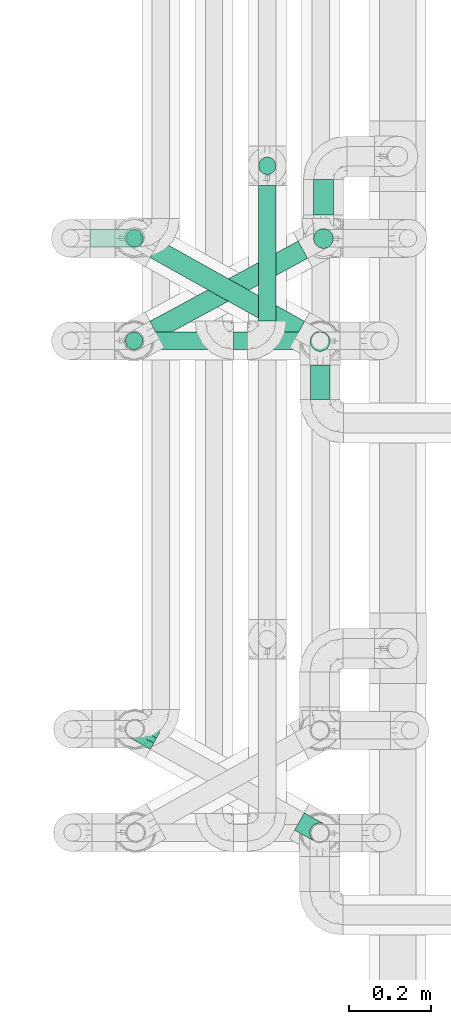
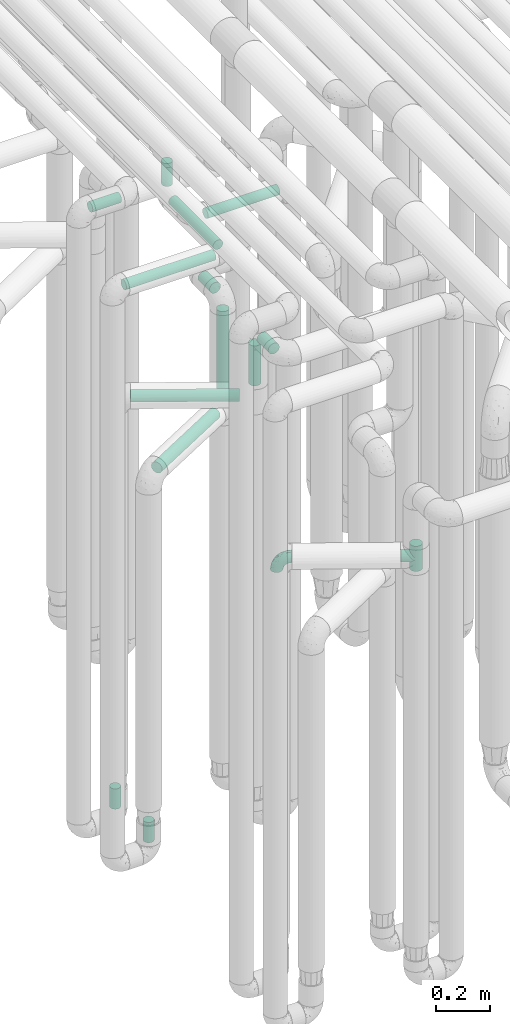
# One storey, part 599 of 827: 13 flow segments, 2 flow fittings.
"""IFC2X3 building model written with IfcOpenShell, lengths in millimetres."""

from ifc_helpers import new_model, entity, si_unit, converted_unit, derived_unit, direction, frame, origin, origin_2d_with_axis, place, context, subcontext, project, spatial, circle, extrude, faceted_brep, source, transform, mapped, material, type_object, type_shapes, element, save


model = new_model("IFC2X3")

# Units and contexts
model_context = context("Model", 3, precision=0.01, world=origin(), true_north=direction((6.12303176911189e-17, 1.0)))
body_context = subcontext(model_context, "Body", "Model", "MODEL_VIEW")
ifc_project = project(units=[si_unit("LENGTHUNIT", "METRE", prefix="MILLI"), si_unit("AREAUNIT", "SQUARE_METRE"), si_unit("VOLUMEUNIT", "CUBIC_METRE"), converted_unit("PLANEANGLEUNIT", "DEGREE", entity("IfcRatioMeasure", 0.0174532925199433), si_unit("PLANEANGLEUNIT", "RADIAN"), dimensions=[0, 0, 0, 0, 0, 0, 0]), si_unit("MASSUNIT", "GRAM", prefix="KILO"), derived_unit("MASSDENSITYUNIT", [(si_unit("MASSUNIT", "GRAM", prefix="KILO"), 1), (si_unit("LENGTHUNIT", "METRE"), -3)]), derived_unit("MOMENTOFINERTIAUNIT", [(si_unit("LENGTHUNIT", "METRE"), 4)]), si_unit("TIMEUNIT", "SECOND"), si_unit("FREQUENCYUNIT", "HERTZ"), si_unit("THERMODYNAMICTEMPERATUREUNIT", "DEGREE_CELSIUS"), derived_unit("THERMALTRANSMITTANCEUNIT", [(si_unit("MASSUNIT", "GRAM", prefix="KILO"), 1), (si_unit("THERMODYNAMICTEMPERATUREUNIT", "KELVIN"), -1), (si_unit("TIMEUNIT", "SECOND"), -3)]), derived_unit("VOLUMETRICFLOWRATEUNIT", [(si_unit("LENGTHUNIT", "METRE"), 3), (si_unit("TIMEUNIT", "SECOND"), -1)]), derived_unit("MASSFLOWRATEUNIT", [(si_unit("MASSUNIT", "GRAM", prefix="KILO"), 1), (si_unit("TIMEUNIT", "SECOND"), -1)]), derived_unit("ROTATIONALFREQUENCYUNIT", [(si_unit("TIMEUNIT", "SECOND"), -1)]), si_unit("ELECTRICCURRENTUNIT", "AMPERE"), si_unit("ELECTRICVOLTAGEUNIT", "VOLT"), si_unit("POWERUNIT", "WATT"), si_unit("FORCEUNIT", "NEWTON", prefix="KILO"), si_unit("ILLUMINANCEUNIT", "LUX"), si_unit("LUMINOUSFLUXUNIT", "LUMEN"), si_unit("LUMINOUSINTENSITYUNIT", "CANDELA"), derived_unit("USERDEFINED", [(si_unit("MASSUNIT", "GRAM", prefix="KILO"), -1), (si_unit("LENGTHUNIT", "METRE"), -2), (si_unit("TIMEUNIT", "SECOND"), 3), (si_unit("LUMINOUSFLUXUNIT", "LUMEN"), 1)]), derived_unit("LINEARVELOCITYUNIT", [(si_unit("LENGTHUNIT", "METRE"), 1), (si_unit("TIMEUNIT", "SECOND"), -1)]), si_unit("PRESSUREUNIT", "PASCAL"), derived_unit("USERDEFINED", [(si_unit("LENGTHUNIT", "METRE"), -2), (si_unit("MASSUNIT", "GRAM", prefix="KILO"), 1), (si_unit("TIMEUNIT", "SECOND"), -2)]), derived_unit("LINEARFORCEUNIT", [(si_unit("MASSUNIT", "GRAM", prefix="KILO"), 1), (si_unit("LENGTHUNIT", "METRE"), 1), (si_unit("TIMEUNIT", "SECOND"), -2), (si_unit("LENGTHUNIT", "METRE"), -1)]), derived_unit("PLANARFORCEUNIT", [(si_unit("MASSUNIT", "GRAM", prefix="KILO"), 1), (si_unit("LENGTHUNIT", "METRE"), 1), (si_unit("TIMEUNIT", "SECOND"), -2), (si_unit("LENGTHUNIT", "METRE"), -2)])], contexts=[model_context])

# Site, building, storey
site_placement = place(None, origin())
site = spatial("IfcSite", under=ifc_project, at=site_placement, CompositionType="ELEMENT")
building_placement = place(site_placement, origin())
building = spatial("IfcBuilding", under=site, at=building_placement, CompositionType="ELEMENT")
storey_placement = place(building_placement, frame((0.0, 0.0, 28200.0)))
storey = spatial("IfcBuildingStorey", under=building, at=storey_placement, Name="08", CompositionType="ELEMENT", Elevation=28200.0)

# Flow segments
pipe_segment_type = type_object("IfcPipeSegmentType", PredefinedType="NOTDEFINED")
flow_segment_1_placement = place(storey_placement, frame((35253.49, 11783.46, 448.0)))
element("IfcFlowSegment", 1, at=flow_segment_1_placement, inside=storey, type_object=pipe_segment_type, context=body_context, shape_type="SweptSolid", body=[
    extrude(circle(Radius=21.15, at=origin_2d_with_axis()), frame((22.75, 22.75, 0.0), z_axis=(0.0, 0.0, 1.0), x_axis=(-1.0, 0.0, 0.0)), (0.0, 0.0, 1.0), 92.0000000000094),
])
flow_segment_2_placement = place(storey_placement, frame((35252.29, 11533.46, 448.0)))
element("IfcFlowSegment", 2, at=flow_segment_2_placement, inside=storey, type_object=pipe_segment_type, context=body_context, shape_type="SweptSolid", body=[
    extrude(circle(Radius=21.15, at=origin_2d_with_axis()), frame((22.75, 22.75, 0.0), z_axis=(0.0, 0.0, 1.0), x_axis=(-1.0, 0.0, 0.0)), (0.0, 0.0, 1.0), 92.0000000000137),
])
flow_segment_3_placement = place(storey_placement, frame((35168.03, 11783.46, 3177.25)))
element("IfcFlowSegment", 3, at=flow_segment_3_placement, inside=storey, type_object=pipe_segment_type, context=body_context, shape_type="SweptSolid", body=[
    extrude(circle(Radius=21.15, at=origin_2d_with_axis()), frame((0.0, 22.75, 22.75), z_axis=(1.0, 0.0, 0.0), x_axis=(0.0, -1.0, 0.0)), (0.0, 0.0, 1.0), 124.000000000024),
])
flow_segment_4_placement = place(storey_placement, frame((35518.03, 11533.42, 3177.25)))
element("IfcFlowSegment", 4, at=flow_segment_4_placement, inside=storey, type_object=pipe_segment_type, context=body_context, shape_type="SweptSolid", body=[
    extrude(circle(Radius=21.15, at=origin_2d_with_axis()), frame((0.0, 22.75, 22.75), z_axis=(1.0, 0.0, 0.0), x_axis=(0.0, 1.0, 0.0)), (0.0, 0.0, 1.0), 307.750000000047),
])
flow_segment_5_placement = place(storey_placement, frame((35168.03, 11533.44, 2977.25)))
element("IfcFlowSegment", 5, at=flow_segment_5_placement, inside=storey, type_object=pipe_segment_type, context=body_context, shape_type="SweptSolid", body=[
    extrude(circle(Radius=21.15, at=origin_2d_with_axis()), frame((0.0, 22.76, 22.75), z_axis=(1.0, -4.58022354030143e-05, 0.0), x_axis=(4.58022354030143e-05, 1.0, 0.0)), (0.0, 0.0, 1.0), 384.054937940216),
])
flow_segment_6_placement = place(storey_placement, frame((35577.35, 11604.18, 2977.25)))
element("IfcFlowSegment", 6, at=flow_segment_6_placement, inside=storey, type_object=pipe_segment_type, context=body_context, shape_type="SweptSolid", body=[
    extrude(circle(Radius=21.15, at=origin_2d_with_axis()), frame((22.75, 0.0, 22.75), z_axis=(0.0, 1.0, 0.0), x_axis=(-1.0, 0.0, 0.0)), (0.0, 0.0, 1.0), 331.019903361199),
])
flow_segment_7_placement = place(storey_placement, frame((35577.35, 11960.46, 3048.0)))
element("IfcFlowSegment", 7, at=flow_segment_7_placement, inside=storey, type_object=pipe_segment_type, context=body_context, shape_type="SweptSolid", body=[
    extrude(circle(Radius=21.15, at=origin_2d_with_axis()), frame((22.75, 22.75, 0.0)), (0.0, 0.0, 1.0), 104.000000000011),
])
flow_segment_8_placement = place(storey_placement, frame((35711.26, 11780.07, 2157.0)))
element("IfcFlowSegment", 8, at=flow_segment_8_placement, inside=storey, type_object=pipe_segment_type, context=body_context, shape_type="SweptSolid", body=[
    extrude(circle(Radius=24.0, at=origin_2d_with_axis()), frame((25.6, 25.6, 0.0), z_axis=(0.0, 0.0, 1.0), x_axis=(-1.0, 0.0, 0.0)), (0.0, 0.0, 1.0), 385.99999999999),
])
flow_segment_9_placement = place(storey_placement, frame((35703.19, 11528.87, 2362.0)))
element("IfcFlowSegment", 9, at=flow_segment_9_placement, inside=storey, type_object=pipe_segment_type, context=body_context, shape_type="SweptSolid", body=[
    extrude(circle(Radius=24.0, at=origin_2d_with_axis()), frame((25.6, 25.6, 0.0), z_axis=(0.0, 0.0, 1.0), x_axis=(-1.0, 0.0, 0.0)), (0.0, 0.0, 1.0), 180.999999999998),
])
flow_segment_10_placement = place(storey_placement, frame((35312.67, 11560.12, 2279.4)))
element("IfcFlowSegment", 10, at=flow_segment_10_placement, inside=storey, type_object=pipe_segment_type, context=body_context, shape_type="SweptSolid", body=[
    extrude(circle(Radius=24.0, at=origin_2d_with_axis()), frame((13.31, 220.18, 25.6), z_axis=(0.872709848733326, -0.488239203591698, 0.0), x_axis=(-0.488239203591698, -0.872709848733326, 0.0)), (0.0, 0.0, 1.0), 404.791381976554),
])
flow_segment_11_placement = place(storey_placement, frame((35312.16, 11560.04, 2074.4)))
element("IfcFlowSegment", 11, at=flow_segment_11_placement, inside=storey, type_object=pipe_segment_type, context=body_context, shape_type="SweptSolid", body=[
    extrude(circle(Radius=24.0, at=origin_2d_with_axis()), frame((13.02, 22.7, 25.6), z_axis=(0.879349860952551, 0.47617625102763, 0.0), x_axis=(0.47617625102763, -0.879349860952551, 0.0)), (0.0, 0.0, 1.0), 411.156212335712),
])
flow_segment_12_placement = place(storey_placement, frame((35711.26, 11862.67, 2574.4)))
element("IfcFlowSegment", 12, at=flow_segment_12_placement, inside=storey, type_object=pipe_segment_type, context=body_context, shape_type="SweptSolid", body=[
    extrude(circle(Radius=24.0, at=origin_2d_with_axis()), frame((25.6, 0.0, 25.6), z_axis=(0.0, 1.0, 0.0), x_axis=(1.0, 0.0, 0.0)), (0.0, 0.0, 1.0), 86.4113062809591),
])
flow_segment_13_placement = place(storey_placement, frame((35703.19, 11413.08, 2574.4)))
element("IfcFlowSegment", 13, at=flow_segment_13_placement, inside=storey, type_object=pipe_segment_type, context=body_context, shape_type="SweptSolid", body=[
    extrude(circle(Radius=24.0, at=origin_2d_with_axis()), frame((25.6, 0.0, 25.6), z_axis=(0.0, 1.0, 0.0), x_axis=(-1.0, 0.0, 0.0)), (0.0, 0.0, 1.0), 84.3822522691391),
])

# Flow fittings
ifc_material = material()
pipe_fitting_type_1 = type_object("IfcPipeFittingType", Name="ADSK_1", PredefinedType="NOTDEFINED", material=ifc_material)
shared_shape_1 = source(origin(), body_context, "Body", "Brep", [
    faceted_brep([(-57.0, 12.07, -20.91), (-57.0, 6.25, -23.33), (-57.0, 0.0, -24.15), (-57.0, -6.25, -23.33), (-57.0, -12.08, -20.91), (-57.0, -17.08, -17.08), (-57.0, -20.91, -12.08), (-57.0, -23.33, -6.25), (-57.0, -24.15, 0.0), (-57.0, -23.33, 6.25), (-57.0, -20.91, 12.07), (-57.0, -17.08, 17.08), (-57.0, -12.08, 20.91), (-57.0, -6.25, 23.33), (-57.0, 0.0, 24.15), (-57.0, 6.25, 23.33), (-57.0, 12.07, 20.91), (-57.0, 17.08, 17.08), (-57.0, 20.91, 12.07), (-57.0, 23.33, 6.25), (-57.0, 24.15, 0.0), (-57.0, 23.33, -6.25), (-57.0, 20.91, -12.08), (-57.0, 17.08, -17.08), (0.0, 57.0, -24.15), (-6.25, 57.0, -23.33), (-12.07, 57.0, -20.91), (-17.08, 57.0, -17.08), (-20.91, 57.0, -12.08), (-23.33, 57.0, -6.25), (-24.15, 57.0, 0.0), (-23.33, 57.0, 6.25), (-20.91, 57.0, 12.07), (-17.08, 57.0, 17.08), (-12.07, 57.0, 20.91), (-6.25, 57.0, 23.33), (0.0, 57.0, 24.15), (6.25, 57.0, 23.33), (12.08, 57.0, 20.91), (17.08, 57.0, 17.08), (20.91, 57.0, 12.07), (23.33, 57.0, 6.25), (24.15, 57.0, 0.0), (23.33, 57.0, -6.25), (20.91, 57.0, -12.08), (17.08, 57.0, -17.08), (12.08, 57.0, -20.91), (6.25, 57.0, -23.33), (14.9, 21.14, 6.17), (13.61, 24.64, 12.48), (6.23, 8.95, 8.98), (-41.47, -21.06, 0.0), (-41.92, -18.38, 13.72), (-24.64, -13.61, 12.48), (-37.37, -13.24, 18.15), (-6.8, -4.93, 8.18), (-21.76, -15.19, 6.22), (-12.78, -9.18, 0.0), (-37.73, -20.51, 7.75), (-7.38, 7.38, 20.24), (-23.37, -4.26, 20.42), (-11.9, -3.19, 15.86), (-42.14, -8.7, 21.82), (13.24, 37.37, 18.15), (9.33, 23.53, 16.85), (4.26, 23.37, 20.42), (2.77, 10.92, 15.55), (-29.46, 0.91, 23.52), (-44.13, 20.56, 15.69), (-39.25, 26.33, 10.88), (-49.02, 22.92, 9.96), (-34.58, 23.87, 17.15), (-15.8, 6.8, 22.81), (-8.67, 20.47, 23.88), (-18.12, 12.9, 24.08), (-48.29, 14.92, 19.65), (-44.06, -2.85, 23.78), (-9.23, 48.95, 22.58), (-3.78, 42.74, 24.07), (-40.34, 4.26, 24.09), (-44.02, 26.14, 5.46), (-44.04, 9.88, 22.74), (-4.95, 16.87, 22.52), (-2.75, 1.43, 12.5), (-25.48, 40.98, 10.71), (20.51, 37.73, 7.75), (18.38, 41.92, 13.72), (8.7, 42.14, 21.82), (-25.95, -17.97, 0.0), (2.85, 44.06, 23.78), (21.06, 41.47, 0.0), (17.97, 25.95, 0.0), (-24.04, -9.27, 17.13), (-33.26, 33.26, 5.86), (-28.55, 40.57, 0.0), (-40.57, 28.55, 0.0), (-25.29, 47.19, 4.06), (-27.01, 31.1, 16.77), (-15.7, 43.95, 19.9), (-20.27, 45.22, 15.61), (-30.53, 31.98, 12.64), (-11.28, 38.33, 22.92), (-9.97, 27.88, 24.09), (-20.15, 30.26, 21.25), (-31.25, 11.75, 23.64), (-28.75, 7.23, 24.15), (-29.53, 18.06, 22.27), (-28.44, 24.21, 20.02), (-37.55, 17.7, 20.26), (-15.88, 29.25, 22.99), (-20.82, 20.82, 23.44), (-0.91, 29.46, 23.52), (-13.5, -7.67, 12.04), (1.49, 1.56, 5.16), (8.86, 10.35, 4.59), (0.38, -0.38, 0.0), (9.18, 12.78, 0.0), (-37.37, -13.24, -18.15), (8.86, 10.35, -4.59), (-45.22, 20.27, -15.61), (-43.95, 15.7, -19.9), (-38.33, 11.28, -22.92), (-48.95, 9.23, -22.58), (-47.19, 25.29, -4.06), (-33.26, 33.26, -5.86), (18.38, 41.92, -13.72), (-30.26, 20.15, -21.25), (2.85, 44.06, -23.78), (-4.26, 40.34, -24.09), (-40.98, 25.48, -10.71), (-41.92, -18.38, -13.72), (9.25, 23.5, -16.92), (4.26, 23.37, -20.42), (13.24, 37.37, -18.15), (-37.73, -20.51, -7.75), (-11.75, 31.25, -23.64), (-7.23, 28.75, -24.15), (-12.9, 18.12, -24.08), (8.7, 42.14, -21.82), (-44.06, -2.85, -23.78), (-6.8, 15.8, -22.81), (-20.47, 8.67, -23.88), (-24.64, -13.61, -12.48), (-42.74, 3.78, -24.07), (-18.06, 29.53, -22.27), (-24.21, 28.44, -20.02), (-27.88, 9.97, -24.09), (-31.1, 27.01, -16.77), (-26.14, 44.02, -5.46), (14.9, 21.14, -6.17), (20.51, 37.73, -7.75), (-9.88, 44.04, -22.74), (-20.56, 44.13, -15.69), (-21.76, -15.19, -6.22), (-13.5, -7.67, -12.04), (-24.14, -9.76, -16.74), (-11.9, -3.19, -15.86), (-14.92, 48.29, -19.65), (-23.37, -4.26, -20.42), (-0.91, 29.46, -23.52), (-26.33, 39.25, -10.88), (-23.87, 34.58, -17.15), (-42.14, -8.7, -21.82), (-22.92, 49.02, -9.96), (13.61, 24.64, -12.48), (-31.98, 30.53, -12.64), (-16.87, 4.95, -22.52), (-17.7, 37.55, -20.26), (-29.25, 15.88, -22.99), (-20.82, 20.82, -23.44), (-29.46, 0.91, -23.52), (-7.38, 7.38, -20.24), (2.77, 10.92, -15.55), (6.23, 8.95, -8.98), (-6.8, -4.93, -8.18), (-2.81, 1.41, -12.54), (1.49, 1.56, -5.16)], [[[0, 1, 2, 3, 4, 5, 6, 7, 8, 9, 10, 11, 12, 13, 14, 15, 16, 17, 18, 19, 20, 21, 22, 23]], [[24, 25, 26, 27, 28, 29, 30, 31, 32, 33, 34, 35, 36, 37, 38, 39, 40, 41, 42, 43, 44, 45, 46, 47]], [[48, 49, 50]], [[9, 8, 51]], [[52, 53, 54]], [[55, 56, 57]], [[10, 58, 52]], [[9, 58, 10]], [[59, 60, 61]], [[54, 12, 11]], [[54, 62, 12]], [[63, 39, 38]], [[64, 65, 66]], [[62, 60, 67]], [[68, 69, 70]], [[71, 69, 68]], [[72, 73, 74]], [[16, 75, 17]], [[13, 76, 14]], [[35, 77, 78]], [[14, 79, 15]], [[17, 68, 18]], [[14, 76, 79]], [[20, 19, 80]], [[70, 19, 18]], [[81, 15, 79]], [[15, 81, 16]], [[73, 72, 82]], [[66, 83, 50]], [[32, 31, 84]], [[85, 86, 49]], [[63, 87, 65]], [[56, 58, 88]], [[36, 89, 37]], [[85, 41, 40]], [[36, 35, 78]], [[90, 41, 85]], [[40, 39, 86]], [[12, 62, 13]], [[86, 85, 40]], [[48, 85, 49]], [[85, 91, 90]], [[87, 38, 37]], [[92, 60, 54]], [[80, 69, 93]], [[93, 94, 95]], [[10, 52, 11]], [[94, 96, 30]], [[97, 98, 99]], [[80, 93, 95]], [[100, 97, 84]], [[99, 98, 33]], [[101, 102, 78]], [[103, 101, 98]], [[96, 31, 30]], [[77, 98, 101]], [[77, 35, 34]], [[34, 33, 98]], [[9, 51, 58]], [[87, 63, 38]], [[104, 105, 74]], [[106, 103, 107]], [[106, 81, 104]], [[75, 68, 17]], [[108, 107, 71]], [[33, 32, 99]], [[109, 103, 110]], [[101, 109, 102]], [[89, 78, 111]], [[53, 52, 58]], [[54, 11, 52]], [[60, 62, 54]], [[88, 58, 51]], [[76, 62, 67]], [[53, 112, 92]], [[60, 59, 72]], [[39, 63, 86]], [[49, 86, 63]], [[89, 87, 37]], [[42, 41, 90]], [[111, 82, 65]], [[111, 65, 87]], [[65, 59, 66]], [[104, 81, 79]], [[75, 81, 108]], [[32, 84, 99]], [[97, 99, 84]], [[98, 97, 103]], [[106, 107, 108]], [[74, 102, 110]], [[111, 78, 102]], [[74, 110, 104]], [[74, 67, 72]], [[61, 92, 112]], [[66, 59, 61]], [[56, 53, 58]], [[66, 50, 49]], [[61, 112, 83]], [[66, 49, 64]], [[78, 89, 36]], [[87, 89, 111]], [[62, 76, 13]], [[79, 76, 67]], [[100, 93, 69]], [[96, 93, 84]], [[55, 113, 50]], [[113, 114, 50]], [[104, 79, 105]], [[106, 104, 110]], [[20, 80, 95]], [[85, 48, 91]], [[115, 114, 113]], [[116, 91, 48]], [[70, 80, 19]], [[93, 96, 94]], [[84, 31, 96]], [[103, 106, 110]], [[81, 106, 108]], [[103, 97, 107]], [[71, 107, 97]], [[71, 97, 100]], [[108, 71, 68]], [[79, 67, 105]], [[67, 74, 105]], [[115, 113, 57]], [[112, 56, 55]], [[56, 88, 57]], [[60, 72, 67]], [[82, 72, 59]], [[65, 82, 59]], [[82, 111, 73]], [[111, 102, 73]], [[102, 74, 73]], [[81, 75, 16]], [[68, 75, 108]], [[68, 70, 18]], [[80, 70, 69]], [[98, 77, 34]], [[78, 77, 101]], [[93, 100, 84]], [[71, 100, 69]], [[102, 109, 110]], [[101, 103, 109]], [[53, 92, 54]], [[61, 60, 92]], [[56, 112, 53]], [[83, 112, 55]], [[50, 83, 55]], [[61, 83, 66]], [[49, 63, 64]], [[65, 64, 63]], [[57, 113, 55]], [[114, 115, 116]], [[116, 48, 114]], [[48, 50, 114]], [[117, 5, 4]], [[116, 115, 118]], [[119, 120, 23]], [[121, 122, 120]], [[95, 123, 20]], [[0, 23, 120]], [[124, 95, 94]], [[125, 45, 44]], [[121, 120, 126]], [[24, 127, 128]], [[22, 21, 129]], [[0, 122, 1]], [[5, 117, 130]], [[131, 132, 133]], [[134, 88, 51]], [[135, 136, 137]], [[6, 5, 130]], [[46, 138, 47]], [[139, 3, 2]], [[140, 141, 137]], [[6, 134, 7]], [[134, 130, 142]], [[143, 2, 1]], [[144, 126, 145]], [[121, 146, 143]], [[147, 120, 119]], [[94, 148, 124]], [[149, 150, 91]], [[30, 29, 148]], [[151, 25, 128]], [[27, 152, 28]], [[134, 153, 88]], [[154, 155, 156]], [[27, 26, 157]], [[151, 26, 25]], [[155, 158, 156]], [[24, 47, 127]], [[1, 122, 143]], [[138, 132, 159]], [[160, 152, 161]], [[24, 128, 25]], [[46, 133, 138]], [[162, 117, 4]], [[148, 160, 124]], [[152, 160, 163]], [[154, 142, 155]], [[45, 125, 133]], [[133, 46, 45]], [[125, 164, 133]], [[51, 7, 134]], [[42, 90, 43]], [[165, 147, 129]], [[153, 134, 142]], [[43, 150, 44]], [[162, 4, 3]], [[141, 140, 166]], [[117, 162, 158]], [[163, 29, 28]], [[43, 90, 150]], [[123, 21, 20]], [[144, 151, 135]], [[157, 152, 27]], [[167, 145, 161]], [[23, 22, 119]], [[168, 126, 169]], [[121, 168, 146]], [[139, 143, 170]], [[142, 130, 117]], [[8, 7, 51]], [[134, 6, 130]], [[139, 162, 3]], [[170, 166, 158]], [[170, 158, 162]], [[158, 171, 156]], [[44, 150, 125]], [[91, 150, 90]], [[164, 125, 150]], [[132, 138, 133]], [[127, 138, 159]], [[131, 164, 172]], [[132, 171, 140]], [[135, 151, 128]], [[157, 151, 167]], [[22, 129, 119]], [[147, 119, 129]], [[120, 147, 126]], [[144, 145, 167]], [[137, 146, 169]], [[170, 143, 146]], [[137, 169, 135]], [[137, 159, 140]], [[171, 172, 156]], [[173, 174, 175]], [[156, 175, 154]], [[174, 57, 153]], [[132, 172, 171]], [[172, 164, 173]], [[143, 139, 2]], [[162, 139, 170]], [[138, 127, 47]], [[128, 127, 159]], [[165, 124, 160]], [[123, 124, 129]], [[149, 173, 164]], [[176, 174, 173]], [[135, 128, 136]], [[144, 135, 169]], [[150, 149, 164]], [[176, 118, 115]], [[149, 91, 116]], [[30, 148, 94]], [[163, 148, 29]], [[124, 123, 95]], [[129, 21, 123]], [[126, 144, 169]], [[151, 144, 167]], [[126, 147, 145]], [[161, 145, 147]], [[161, 147, 165]], [[167, 161, 152]], [[128, 159, 136]], [[159, 137, 136]], [[154, 153, 142]], [[132, 140, 159]], [[174, 176, 57]], [[57, 88, 153]], [[166, 140, 171]], [[158, 166, 171]], [[166, 170, 141]], [[170, 146, 141]], [[146, 137, 141]], [[151, 157, 26]], [[152, 157, 167]], [[152, 163, 28]], [[148, 163, 160]], [[120, 122, 0]], [[143, 122, 121]], [[124, 165, 129]], [[161, 165, 160]], [[146, 168, 169]], [[121, 126, 168]], [[142, 117, 155]], [[158, 155, 117]], [[175, 156, 172]], [[153, 154, 174]], [[173, 175, 172]], [[174, 154, 175]], [[164, 131, 133]], [[172, 132, 131]], [[176, 173, 118]], [[57, 176, 115]], [[173, 149, 118]], [[149, 116, 118]]]),
])
type_shapes(pipe_fitting_type_1, [shared_shape_1])
flow_fitting_1_placement = place(storey_placement, frame((35276.74, 10609.13, 2305.0), z_axis=(-0.4889196285334, -0.872328835264983, 0.0), x_axis=(-0.872328835264983, 0.4889196285334, 0.0)))
element("IfcFlowFitting", 14, at=flow_fitting_1_placement, inside=storey, type_object=pipe_fitting_type_1, material=ifc_material, Name="ADSK_1", ObjectType="ADSK_1", context=body_context, shape_type="MappedRepresentation", body=[
    mapped(shared_shape_1, transform((0.0, 0.0, 0.0), scale=1.0)),
])
pipe_fitting_type_2 = type_object("IfcPipeFittingType", Name="ADSK_1", PredefinedType="NOTDEFINED", material=ifc_material)
shared_shape_2 = source(origin(), body_context, "Body", "Brep", [
    faceted_brep([(-57.0, 12.07, -20.91), (-57.0, 6.25, -23.33), (-57.0, 0.0, -24.15), (-57.0, -6.25, -23.33), (-57.0, -12.08, -20.91), (-57.0, -17.08, -17.08), (-57.0, -20.91, -12.08), (-57.0, -23.33, -6.25), (-57.0, -24.15, 0.0), (-57.0, -23.33, 6.25), (-57.0, -20.91, 12.07), (-57.0, -17.08, 17.08), (-57.0, -12.08, 20.91), (-57.0, -6.25, 23.33), (-57.0, 0.0, 24.15), (-57.0, 6.25, 23.33), (-57.0, 12.07, 20.91), (-57.0, 17.08, 17.08), (-57.0, 20.91, 12.07), (-57.0, 23.33, 6.25), (-57.0, 24.15, 0.0), (-57.0, 23.33, -6.25), (-57.0, 20.91, -12.08), (-57.0, 17.08, -17.08), (57.0, 0.0, -24.15), (57.0, 6.25, -23.33), (57.0, 12.07, -20.91), (57.0, 17.08, -17.08), (57.0, 20.91, -12.08), (57.0, 23.33, -6.25), (57.0, 24.15, 0.0), (57.0, 23.33, 6.25), (57.0, 20.91, 12.07), (57.0, 17.08, 17.08), (57.0, 12.07, 20.91), (57.0, 6.25, 23.33), (57.0, 0.0, 24.15), (57.0, -6.25, 23.33), (57.0, -12.08, 20.91), (57.0, -17.08, 17.08), (57.0, -20.91, 12.07), (57.0, -23.33, 6.25), (57.0, -24.15, 0.0), (57.0, -23.33, -6.25), (57.0, -20.91, -12.08), (57.0, -17.08, -17.08), (57.0, -12.08, -20.91), (57.0, -6.25, -23.33), (23.27, -23.27, 6.45), (24.15, -24.15, 0.0), (-24.15, -24.15, 0.0), (20.9, -20.9, 12.1), (13.54, -13.54, 20.0), (17.52, -17.52, 16.62), (-23.27, -23.27, 6.45), (-20.9, -20.9, 12.1), (-17.52, -17.52, 16.62), (-13.54, -13.54, 20.0), (-9.19, -9.19, 22.33), (9.19, -9.19, 22.33), (4.64, -4.64, 23.7), (0.0, 0.0, 24.15), (-4.64, -4.64, 23.7), (4.64, -4.64, -23.7), (0.0, 0.0, -24.15), (-4.64, -4.64, -23.7), (-9.19, -9.19, -22.33), (9.19, -9.19, -22.33), (13.54, -13.54, -20.0), (17.52, -17.52, -16.62), (20.9, -20.9, -12.1), (23.27, -23.27, -6.45), (-13.54, -13.54, -20.0), (-17.52, -17.52, -16.62), (-23.27, -23.27, -6.45), (-20.9, -20.9, -12.1), (0.0, -57.0, -24.15), (6.25, -57.0, -23.33), (12.08, -57.0, -20.91), (17.08, -57.0, -17.08), (20.91, -57.0, -12.08), (23.33, -57.0, -6.25), (24.15, -57.0, 0.0), (23.33, -57.0, 6.25), (20.91, -57.0, 12.07), (17.08, -57.0, 17.08), (12.08, -57.0, 20.91), (6.25, -57.0, 23.33), (0.0, -57.0, 24.15), (-6.25, -57.0, 23.33), (-12.07, -57.0, 20.91), (-17.08, -57.0, 17.08), (-20.91, -57.0, 12.07), (-23.33, -57.0, 6.25), (-24.15, -57.0, 0.0), (-23.33, -57.0, -6.25), (-20.91, -57.0, -12.08), (-17.08, -57.0, -17.08), (-12.07, -57.0, -20.91), (-6.25, -57.0, -23.33)], [[[0, 1, 2, 3, 4, 5, 6, 7, 8, 9, 10, 11, 12, 13, 14, 15, 16, 17, 18, 19, 20, 21, 22, 23]], [[24, 25, 26, 27, 28, 29, 30, 31, 32, 33, 34, 35, 36, 37, 38, 39, 40, 41, 42, 43, 44, 45, 46, 47]], [[41, 40, 48]], [[42, 41, 49]], [[50, 9, 8]], [[49, 41, 48]], [[40, 51, 48]], [[39, 38, 52]], [[51, 40, 53]], [[52, 53, 39]], [[53, 40, 39]], [[50, 54, 9]], [[9, 54, 10]], [[54, 55, 10]], [[56, 57, 11]], [[11, 10, 56]], [[11, 57, 12]], [[56, 10, 55]], [[12, 57, 58]], [[52, 38, 59]], [[60, 36, 61]], [[62, 61, 14]], [[59, 37, 60]], [[37, 59, 38]], [[60, 37, 36]], [[61, 36, 35, 15, 14]], [[32, 31, 19, 18]], [[17, 16, 34, 33]], [[18, 17, 33, 32]], [[35, 34, 16, 15]], [[20, 19, 31, 30]], [[62, 13, 58]], [[13, 62, 14]], [[58, 13, 12]], [[27, 23, 22, 28]], [[22, 21, 29, 28]], [[0, 23, 27, 26]], [[20, 30, 29, 21]], [[24, 47, 63]], [[24, 64, 2, 1, 25]], [[64, 24, 63]], [[2, 64, 65]], [[26, 25, 1, 0]], [[65, 66, 3]], [[2, 65, 3]], [[66, 4, 3]], [[63, 47, 67]], [[46, 45, 68]], [[69, 68, 45]], [[44, 70, 69]], [[69, 45, 44]], [[46, 68, 67]], [[43, 42, 49]], [[7, 50, 8]], [[43, 71, 44]], [[71, 43, 49]], [[44, 71, 70]], [[72, 4, 66]], [[72, 5, 4]], [[5, 72, 73]], [[5, 73, 6]], [[74, 50, 7]], [[75, 74, 6]], [[74, 7, 6]], [[75, 6, 73]], [[46, 67, 47]], [[76, 77, 78, 79, 80, 81, 82, 83, 84, 85, 86, 87, 88, 89, 90, 91, 92, 93, 94, 95, 96, 97, 98, 99]], [[50, 94, 93]], [[54, 50, 93]], [[91, 90, 57]], [[56, 92, 91]], [[54, 93, 92]], [[58, 90, 89]], [[55, 54, 92]], [[56, 55, 92]], [[58, 57, 90]], [[88, 61, 62]], [[58, 89, 62]], [[56, 91, 57]], [[62, 89, 88]], [[60, 88, 87]], [[86, 59, 87]], [[84, 83, 48]], [[53, 85, 84]], [[52, 86, 85]], [[49, 83, 82]], [[59, 60, 87]], [[52, 59, 86]], [[49, 48, 83]], [[51, 53, 84]], [[48, 51, 84]], [[52, 85, 53]], [[88, 60, 61]], [[82, 81, 49]], [[71, 49, 81]], [[69, 80, 79]], [[79, 78, 68]], [[71, 81, 80]], [[67, 78, 77]], [[70, 71, 80]], [[69, 70, 80]], [[67, 68, 78]], [[76, 64, 63]], [[67, 77, 63]], [[69, 79, 68]], [[63, 77, 76]], [[65, 76, 99]], [[98, 66, 99]], [[96, 95, 74]], [[73, 97, 96]], [[72, 98, 97]], [[50, 95, 94]], [[66, 65, 99]], [[72, 66, 98]], [[50, 74, 95]], [[75, 73, 96]], [[74, 75, 96]], [[72, 97, 73]], [[76, 65, 64]]]),
])
type_shapes(pipe_fitting_type_2, [shared_shape_2])
flow_fitting_2_placement = place(storey_placement, frame((35728.05, 10356.17, 2305.0), z_axis=(-0.489031571945667, -0.87226608419699, 0.0), x_axis=(0.0, 0.0, -1.0)))
element("IfcFlowFitting", 15, at=flow_fitting_2_placement, inside=storey, type_object=pipe_fitting_type_2, material=ifc_material, Name="ADSK_1", ObjectType="ADSK_1", context=body_context, shape_type="MappedRepresentation", body=[
    mapped(shared_shape_2, transform((0.0, 0.0, 0.0), scale=1.0)),
])

save(model, "model.ifc")
